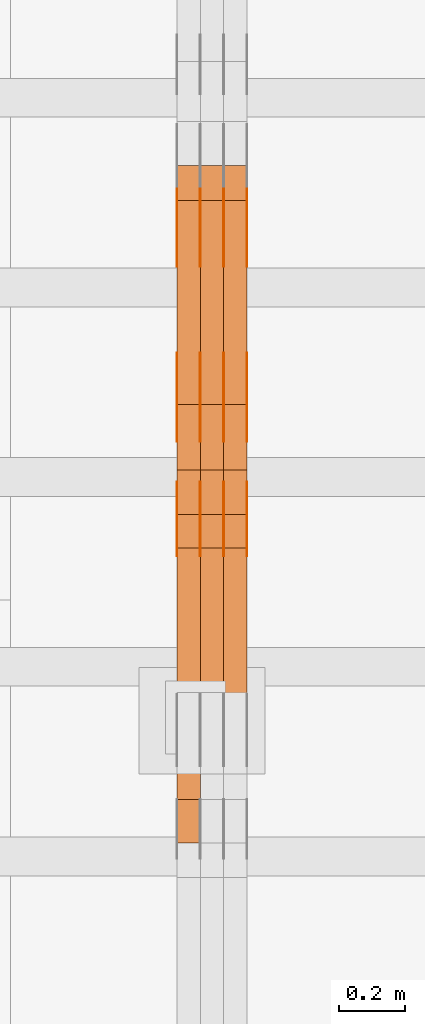
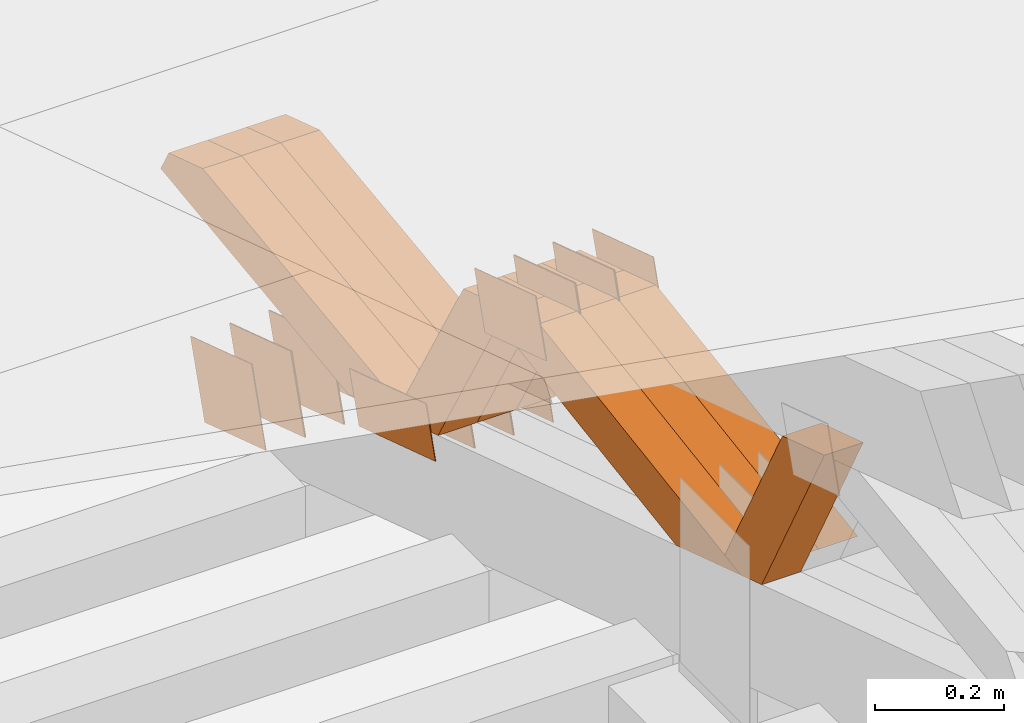
# One storey, part 164 of 385: 28 proxies.
"""IFC2X3 building model written with IfcOpenShell, lengths in millimetres."""

from ifc_helpers import new_model, entity, si_unit, converted_unit, derived_unit, direction, frame, origin, place, context, subcontext, project, spatial, polyline, outline, extrude, source, transform, mapped, material, type_object, type_shapes, element, save


model = new_model("IFC2X3")

# Units and contexts
model_context = context("Model", 3, precision=0.01, world=origin(), true_north=direction((6.12303176911189e-17, 1.0)))
body_context = subcontext(model_context, "Body", "Model", "MODEL_VIEW")
ifc_project = project(units=[si_unit("LENGTHUNIT", "METRE", prefix="MILLI"), si_unit("AREAUNIT", "SQUARE_METRE"), si_unit("VOLUMEUNIT", "CUBIC_METRE"), converted_unit("PLANEANGLEUNIT", "DEGREE", entity("IfcRatioMeasure", 0.0174532925199433), si_unit("PLANEANGLEUNIT", "RADIAN"), dimensions=[0, 0, 0, 0, 0, 0, 0]), si_unit("MASSUNIT", "GRAM", prefix="KILO"), derived_unit("MASSDENSITYUNIT", [(si_unit("MASSUNIT", "GRAM", prefix="KILO"), 1), (si_unit("LENGTHUNIT", "METRE"), -3)]), si_unit("TIMEUNIT", "SECOND"), si_unit("FREQUENCYUNIT", "HERTZ"), si_unit("THERMODYNAMICTEMPERATUREUNIT", "DEGREE_CELSIUS"), derived_unit("THERMALTRANSMITTANCEUNIT", [(si_unit("MASSUNIT", "GRAM", prefix="KILO"), 1), (si_unit("THERMODYNAMICTEMPERATUREUNIT", "KELVIN"), -1), (si_unit("TIMEUNIT", "SECOND"), -3)]), derived_unit("VOLUMETRICFLOWRATEUNIT", [(si_unit("LENGTHUNIT", "METRE"), 3), (si_unit("TIMEUNIT", "SECOND"), -1)]), si_unit("ELECTRICCURRENTUNIT", "AMPERE"), si_unit("ELECTRICVOLTAGEUNIT", "VOLT"), si_unit("POWERUNIT", "WATT"), si_unit("FORCEUNIT", "NEWTON", prefix="KILO"), si_unit("ILLUMINANCEUNIT", "LUX"), si_unit("LUMINOUSFLUXUNIT", "LUMEN"), si_unit("LUMINOUSINTENSITYUNIT", "CANDELA"), derived_unit("USERDEFINED", [(si_unit("MASSUNIT", "GRAM", prefix="KILO"), -1), (si_unit("LENGTHUNIT", "METRE"), -2), (si_unit("TIMEUNIT", "SECOND"), 3), (si_unit("LUMINOUSFLUXUNIT", "LUMEN"), 1)]), derived_unit("LINEARVELOCITYUNIT", [(si_unit("LENGTHUNIT", "METRE"), 1), (si_unit("TIMEUNIT", "SECOND"), -1)]), si_unit("PRESSUREUNIT", "PASCAL"), derived_unit("USERDEFINED", [(si_unit("LENGTHUNIT", "METRE"), -2), (si_unit("MASSUNIT", "GRAM", prefix="KILO"), 1), (si_unit("TIMEUNIT", "SECOND"), -2)])], contexts=[model_context])

# Site, building, storey
site_placement = place(None, origin())
site = spatial("IfcSite", under=ifc_project, at=site_placement, CompositionType="ELEMENT")
building_placement = place(site_placement, origin())
building = spatial("IfcBuilding", under=site, at=building_placement, CompositionType="ELEMENT")
storey_placement = place(building_placement, origin())
storey = spatial("IfcBuildingStorey", under=building, at=storey_placement, Name="Default", CompositionType="ELEMENT", Elevation=0.0)

# Proxies
ifc_material_1 = material(Name="IfcSurfaceStyle #307990")
building_element_proxy_type_1 = type_object("IfcBuildingElementProxyType", PredefinedType="NOTDEFINED", material=ifc_material_1)
shared_shape_1 = source(origin(), body_context, "Body", "SweptSolid", [
    extrude(outline(polyline([(-125.00031378339, -47.9999612158856), (125.000225258022, -47.9999612158856), (124.999811678525, 47.9999612158856), (-124.999723153156, 47.9999612158856), (-125.00031378339, -47.9999612158856)])), frame((125.000225258022, 48.0000091013474, 0.0), z_axis=(0.0, 0.0, 1.0), x_axis=(-1.0, 0.0, 0.0)), (0.0, 0.0, 1.0), 1.3),
])
type_shapes(building_element_proxy_type_1, [shared_shape_1])
proxy_1_placement = place(building_placement, frame((24386.3, 18456.8597683375, 2657.46691321253), z_axis=(-1.0, 0.0, 0.0), x_axis=(0.0, -0.951056516295124, 0.309016994375039)))
element("IfcBuildingElementProxy", 1, at=proxy_1_placement, inside=storey, type_object=building_element_proxy_type_1, material=ifc_material_1, context=body_context, shape_type="MappedRepresentation", body=[
    mapped(shared_shape_1, transform((0.0, 0.0, 0.0), scale=1.0)),
])
ifc_material_2 = material(Name="IfcSurfaceStyle #307933")
building_element_proxy_type_2 = type_object("IfcBuildingElementProxyType", PredefinedType="NOTDEFINED", material=ifc_material_2)
shared_shape_2 = source(origin(), body_context, "Body", "SweptSolid", [
    extrude(outline(polyline([(-125.00031378339, -47.9999612158856), (125.000225258022, -47.9999612158856), (124.999811678525, 47.9999612158856), (-124.999723153156, 47.9999612158856), (-125.00031378339, -47.9999612158856)])), frame((125.000225258022, 48.0000091013474, 0.0), z_axis=(0.0, 0.0, 1.0), x_axis=(-1.0, 0.0, 0.0)), (0.0, 0.0, 1.0), 1.3),
])
type_shapes(building_element_proxy_type_2, [shared_shape_2])
proxy_2_placement = place(building_placement, frame((24315.0, 18456.8597683375, 2657.46691321253), z_axis=(-1.0, 0.0, 0.0), x_axis=(0.0, -0.951056516295124, 0.309016994375039)))
element("IfcBuildingElementProxy", 2, at=proxy_2_placement, inside=storey, type_object=building_element_proxy_type_2, material=ifc_material_2, context=body_context, shape_type="MappedRepresentation", body=[
    mapped(shared_shape_2, transform((0.0, 0.0, 0.0), scale=1.0)),
])
ifc_material_3 = material(Name="IfcSurfaceStyle #307876")
building_element_proxy_type_3 = type_object("IfcBuildingElementProxyType", PredefinedType="NOTDEFINED", material=ifc_material_3)
shared_shape_3 = source(origin(), body_context, "Body", "SweptSolid", [
    extrude(outline(polyline([(-125.00031378339, -47.9999612158856), (125.000225258022, -47.9999612158856), (124.999811678525, 47.9999612158856), (-124.999723153156, 47.9999612158856), (-125.00031378339, -47.9999612158856)])), frame((125.000225258022, 48.0000091013474, 0.0), z_axis=(0.0, 0.0, 1.0), x_axis=(-1.0, 0.0, 0.0)), (0.0, 0.0, 1.0), 1.3),
])
type_shapes(building_element_proxy_type_3, [shared_shape_3])
proxy_3_placement = place(building_placement, frame((24316.3, 18456.8597683375, 2657.46691321253), z_axis=(-1.0, 0.0, 0.0), x_axis=(0.0, -0.951056516295124, 0.309016994375039)))
element("IfcBuildingElementProxy", 3, at=proxy_3_placement, inside=storey, type_object=building_element_proxy_type_3, material=ifc_material_3, context=body_context, shape_type="MappedRepresentation", body=[
    mapped(shared_shape_3, transform((0.0, 0.0, 0.0), scale=1.0)),
])
ifc_material_4 = material(Name="IfcSurfaceStyle #307819")
building_element_proxy_type_4 = type_object("IfcBuildingElementProxyType", PredefinedType="NOTDEFINED", material=ifc_material_4)
shared_shape_4 = source(origin(), body_context, "Body", "SweptSolid", [
    extrude(outline(polyline([(-125.00031378339, -47.9999612158856), (125.000225258022, -47.9999612158856), (124.999811678525, 47.9999612158856), (-124.999723153156, 47.9999612158856), (-125.00031378339, -47.9999612158856)])), frame((125.000225258022, 48.0000091013474, 0.0), z_axis=(0.0, 0.0, 1.0), x_axis=(-1.0, 0.0, 0.0)), (0.0, 0.0, 1.0), 1.29999999999998),
])
type_shapes(building_element_proxy_type_4, [shared_shape_4])
proxy_4_placement = place(building_placement, frame((24245.0, 18456.8597683375, 2657.46691321253), z_axis=(-1.0, 0.0, 0.0), x_axis=(0.0, -0.951056516295124, 0.309016994375039)))
element("IfcBuildingElementProxy", 4, at=proxy_4_placement, inside=storey, type_object=building_element_proxy_type_4, material=ifc_material_4, context=body_context, shape_type="MappedRepresentation", body=[
    mapped(shared_shape_4, transform((0.0, 0.0, 0.0), scale=1.0)),
])
ifc_material_5 = material(Name="IfcSurfaceStyle #307762")
building_element_proxy_type_5 = type_object("IfcBuildingElementProxyType", PredefinedType="NOTDEFINED", material=ifc_material_5)
shared_shape_5 = source(origin(), body_context, "Body", "SweptSolid", [
    extrude(outline(polyline([(-125.00031378339, -47.9999612158856), (125.000225258022, -47.9999612158856), (124.999811678525, 47.9999612158856), (-124.999723153156, 47.9999612158856), (-125.00031378339, -47.9999612158856)])), frame((125.000225258022, 48.0000091013474, 0.0), z_axis=(0.0, 0.0, 1.0), x_axis=(-1.0, 0.0, 0.0)), (0.0, 0.0, 1.0), 1.29999999999998),
])
type_shapes(building_element_proxy_type_5, [shared_shape_5])
proxy_5_placement = place(building_placement, frame((24246.3, 18456.8597683375, 2657.46691321253), z_axis=(-1.0, 0.0, 0.0), x_axis=(0.0, -0.951056516295124, 0.309016994375039)))
element("IfcBuildingElementProxy", 5, at=proxy_5_placement, inside=storey, type_object=building_element_proxy_type_5, material=ifc_material_5, context=body_context, shape_type="MappedRepresentation", body=[
    mapped(shared_shape_5, transform((0.0, 0.0, 0.0), scale=1.0)),
])
ifc_material_6 = material(Name="IfcSurfaceStyle #307705")
building_element_proxy_type_6 = type_object("IfcBuildingElementProxyType", PredefinedType="NOTDEFINED", material=ifc_material_6)
shared_shape_6 = source(origin(), body_context, "Body", "SweptSolid", [
    extrude(outline(polyline([(-125.00031378339, -47.9999612158856), (125.000225258022, -47.9999612158856), (124.999811678525, 47.9999612158856), (-124.999723153156, 47.9999612158856), (-125.00031378339, -47.9999612158856)])), frame((125.000225258022, 48.0000091013474, 0.0), z_axis=(0.0, 0.0, 1.0), x_axis=(-1.0, 0.0, 0.0)), (0.0, 0.0, 1.0), 1.29999999999998),
])
type_shapes(building_element_proxy_type_6, [shared_shape_6])
proxy_6_placement = place(building_placement, frame((24175.0, 18456.8597683375, 2657.46691321253), z_axis=(-1.0, 0.0, 0.0), x_axis=(0.0, -0.951056516295124, 0.309016994375039)))
element("IfcBuildingElementProxy", 6, at=proxy_6_placement, inside=storey, type_object=building_element_proxy_type_6, material=ifc_material_6, context=body_context, shape_type="MappedRepresentation", body=[
    mapped(shared_shape_6, transform((0.0, 0.0, 0.0), scale=1.0)),
])
ifc_material_7 = material(Name="IfcSurfaceStyle #306280")
building_element_proxy_type_7 = type_object("IfcBuildingElementProxyType", PredefinedType="NOTDEFINED", material=ifc_material_7)
shared_shape_7 = source(origin(), body_context, "Body", "SweptSolid", [
    extrude(outline(polyline([(-99.999796294464, -72.0000050220467), (99.9998768370438, -72.0000050220467), (100.000260677528, 72.0000050220467), (-100.000341220108, 72.0000050220467), (-99.999796294464, -72.0000050220467)])), frame((100.000260677528, 72.0000050220467, 0.0), z_axis=(0.0, 0.0, 1.0), x_axis=(-1.0, 0.0, 0.0)), (0.0, 0.0, 1.0), 1.3),
])
type_shapes(building_element_proxy_type_7, [shared_shape_7])
proxy_7_placement = place(building_placement, frame((24386.3, 18936.3876569477, 2373.90613192527), z_axis=(-1.0, 0.0, 0.0), x_axis=(0.0, -0.951056516295124, 0.309016994375039)))
element("IfcBuildingElementProxy", 7, at=proxy_7_placement, inside=storey, type_object=building_element_proxy_type_7, material=ifc_material_7, context=body_context, shape_type="MappedRepresentation", body=[
    mapped(shared_shape_7, transform((0.0, 0.0, 0.0), scale=1.0)),
])
ifc_material_8 = material(Name="IfcSurfaceStyle #306223")
building_element_proxy_type_8 = type_object("IfcBuildingElementProxyType", PredefinedType="NOTDEFINED", material=ifc_material_8)
shared_shape_8 = source(origin(), body_context, "Body", "SweptSolid", [
    extrude(outline(polyline([(-99.999796294464, -72.0000050220467), (99.9998768370438, -72.0000050220467), (100.000260677528, 72.0000050220467), (-100.000341220108, 72.0000050220467), (-99.999796294464, -72.0000050220467)])), frame((100.000260677528, 72.0000050220467, 0.0), z_axis=(0.0, 0.0, 1.0), x_axis=(-1.0, 0.0, 0.0)), (0.0, 0.0, 1.0), 1.3),
])
type_shapes(building_element_proxy_type_8, [shared_shape_8])
proxy_8_placement = place(building_placement, frame((24315.0, 18936.3876569477, 2373.90613192527), z_axis=(-1.0, 0.0, 0.0), x_axis=(0.0, -0.951056516295124, 0.309016994375039)))
element("IfcBuildingElementProxy", 8, at=proxy_8_placement, inside=storey, type_object=building_element_proxy_type_8, material=ifc_material_8, context=body_context, shape_type="MappedRepresentation", body=[
    mapped(shared_shape_8, transform((0.0, 0.0, 0.0), scale=1.0)),
])
ifc_material_9 = material(Name="IfcSurfaceStyle #306166")
building_element_proxy_type_9 = type_object("IfcBuildingElementProxyType", PredefinedType="NOTDEFINED", material=ifc_material_9)
shared_shape_9 = source(origin(), body_context, "Body", "SweptSolid", [
    extrude(outline(polyline([(-99.999796294464, -72.0000050220467), (99.9998768370438, -72.0000050220467), (100.000260677528, 72.0000050220467), (-100.000341220108, 72.0000050220467), (-99.999796294464, -72.0000050220467)])), frame((100.000260677528, 72.0000050220467, 0.0), z_axis=(0.0, 0.0, 1.0), x_axis=(-1.0, 0.0, 0.0)), (0.0, 0.0, 1.0), 1.3),
])
type_shapes(building_element_proxy_type_9, [shared_shape_9])
proxy_9_placement = place(building_placement, frame((24316.3, 18936.3876569477, 2373.90613192527), z_axis=(-1.0, 0.0, 0.0), x_axis=(0.0, -0.951056516295124, 0.309016994375039)))
element("IfcBuildingElementProxy", 9, at=proxy_9_placement, inside=storey, type_object=building_element_proxy_type_9, material=ifc_material_9, context=body_context, shape_type="MappedRepresentation", body=[
    mapped(shared_shape_9, transform((0.0, 0.0, 0.0), scale=1.0)),
])
ifc_material_10 = material(Name="IfcSurfaceStyle #306109")
building_element_proxy_type_10 = type_object("IfcBuildingElementProxyType", PredefinedType="NOTDEFINED", material=ifc_material_10)
shared_shape_10 = source(origin(), body_context, "Body", "SweptSolid", [
    extrude(outline(polyline([(-99.999796294464, -72.0000050220467), (99.9998768370438, -72.0000050220467), (100.000260677528, 72.0000050220467), (-100.000341220108, 72.0000050220467), (-99.999796294464, -72.0000050220467)])), frame((100.000260677528, 72.0000050220467, 0.0), z_axis=(0.0, 0.0, 1.0), x_axis=(-1.0, 0.0, 0.0)), (0.0, 0.0, 1.0), 1.29999999999998),
])
type_shapes(building_element_proxy_type_10, [shared_shape_10])
proxy_10_placement = place(building_placement, frame((24245.0, 18936.3876569477, 2373.90613192527), z_axis=(-1.0, 0.0, 0.0), x_axis=(0.0, -0.951056516295124, 0.309016994375039)))
element("IfcBuildingElementProxy", 10, at=proxy_10_placement, inside=storey, type_object=building_element_proxy_type_10, material=ifc_material_10, context=body_context, shape_type="MappedRepresentation", body=[
    mapped(shared_shape_10, transform((0.0, 0.0, 0.0), scale=1.0)),
])
ifc_material_11 = material(Name="IfcSurfaceStyle #306052")
building_element_proxy_type_11 = type_object("IfcBuildingElementProxyType", PredefinedType="NOTDEFINED", material=ifc_material_11)
shared_shape_11 = source(origin(), body_context, "Body", "SweptSolid", [
    extrude(outline(polyline([(-99.999796294464, -72.0000050220467), (99.9998768370438, -72.0000050220467), (100.000260677528, 72.0000050220467), (-100.000341220108, 72.0000050220467), (-99.999796294464, -72.0000050220467)])), frame((100.000260677528, 72.0000050220467, 0.0), z_axis=(0.0, 0.0, 1.0), x_axis=(-1.0, 0.0, 0.0)), (0.0, 0.0, 1.0), 1.29999999999998),
])
type_shapes(building_element_proxy_type_11, [shared_shape_11])
proxy_11_placement = place(building_placement, frame((24246.3, 18936.3876569477, 2373.90613192527), z_axis=(-1.0, 0.0, 0.0), x_axis=(0.0, -0.951056516295124, 0.309016994375039)))
element("IfcBuildingElementProxy", 11, at=proxy_11_placement, inside=storey, type_object=building_element_proxy_type_11, material=ifc_material_11, context=body_context, shape_type="MappedRepresentation", body=[
    mapped(shared_shape_11, transform((0.0, 0.0, 0.0), scale=1.0)),
])
ifc_material_12 = material(Name="IfcSurfaceStyle #305995")
building_element_proxy_type_12 = type_object("IfcBuildingElementProxyType", PredefinedType="NOTDEFINED", material=ifc_material_12)
shared_shape_12 = source(origin(), body_context, "Body", "SweptSolid", [
    extrude(outline(polyline([(-99.999796294464, -72.0000050220467), (99.9998768370438, -72.0000050220467), (100.000260677528, 72.0000050220467), (-100.000341220108, 72.0000050220467), (-99.999796294464, -72.0000050220467)])), frame((100.000260677528, 72.0000050220467, 0.0), z_axis=(0.0, 0.0, 1.0), x_axis=(-1.0, 0.0, 0.0)), (0.0, 0.0, 1.0), 1.29999999999999),
])
type_shapes(building_element_proxy_type_12, [shared_shape_12])
proxy_12_placement = place(building_placement, frame((24175.0, 18936.3876569477, 2373.90613192527), z_axis=(-1.0, 0.0, 0.0), x_axis=(0.0, -0.951056516295124, 0.309016994375039)))
element("IfcBuildingElementProxy", 12, at=proxy_12_placement, inside=storey, type_object=building_element_proxy_type_12, material=ifc_material_12, context=body_context, shape_type="MappedRepresentation", body=[
    mapped(shared_shape_12, transform((0.0, 0.0, 0.0), scale=1.0)),
])
ifc_material_13 = material(Name="IfcSurfaceStyle #301834")
building_element_proxy_type_13 = type_object("IfcBuildingElementProxyType", PredefinedType="NOTDEFINED", material=ifc_material_13)
shared_shape_13 = source(origin(), body_context, "Body", "SweptSolid", [
    extrude(outline(polyline([(-99.9999427841299, -54.0000599375792), (99.9996549037756, -54.0000599375792), (100.000407167194, 54.0000599375792), (-100.00011928684, 54.0000599375792), (-99.9999427841299, -54.0000599375792)])), frame((100.000407167194, 54.0000599375792, 0.0), z_axis=(0.0, 0.0, 1.0), x_axis=(-1.0, 0.0, 0.0)), (0.0, 0.0, 1.0), 1.3),
])
type_shapes(building_element_proxy_type_13, [shared_shape_13])
proxy_13_placement = place(building_placement, frame((24386.3, 18065.0682492591, 3072.55239547302), z_axis=(-1.0, 0.0, 0.0), x_axis=(0.0, -0.951056516295154, 0.309016994374948)))
element("IfcBuildingElementProxy", 13, at=proxy_13_placement, inside=storey, type_object=building_element_proxy_type_13, material=ifc_material_13, context=body_context, shape_type="MappedRepresentation", body=[
    mapped(shared_shape_13, transform((0.0, 0.0, 0.0), scale=1.0)),
])
ifc_material_14 = material(Name="IfcSurfaceStyle #301777")
building_element_proxy_type_14 = type_object("IfcBuildingElementProxyType", PredefinedType="NOTDEFINED", material=ifc_material_14)
shared_shape_14 = source(origin(), body_context, "Body", "SweptSolid", [
    extrude(outline(polyline([(-99.9999427841299, -54.0000599375792), (99.9996549037756, -54.0000599375792), (100.000407167194, 54.0000599375792), (-100.00011928684, 54.0000599375792), (-99.9999427841299, -54.0000599375792)])), frame((100.000407167194, 54.0000599375792, 0.0), z_axis=(0.0, 0.0, 1.0), x_axis=(-1.0, 0.0, 0.0)), (0.0, 0.0, 1.0), 1.3),
])
type_shapes(building_element_proxy_type_14, [shared_shape_14])
proxy_14_placement = place(building_placement, frame((24315.0, 18065.0682492591, 3072.55239547302), z_axis=(-1.0, 0.0, 0.0), x_axis=(0.0, -0.951056516295154, 0.309016994374948)))
element("IfcBuildingElementProxy", 14, at=proxy_14_placement, inside=storey, type_object=building_element_proxy_type_14, material=ifc_material_14, context=body_context, shape_type="MappedRepresentation", body=[
    mapped(shared_shape_14, transform((0.0, 0.0, 0.0), scale=1.0)),
])
ifc_material_15 = material(Name="IfcSurfaceStyle #301720")
building_element_proxy_type_15 = type_object("IfcBuildingElementProxyType", PredefinedType="NOTDEFINED", material=ifc_material_15)
shared_shape_15 = source(origin(), body_context, "Body", "SweptSolid", [
    extrude(outline(polyline([(-99.9999427841299, -54.0000599375792), (99.9996549037756, -54.0000599375792), (100.000407167194, 54.0000599375792), (-100.00011928684, 54.0000599375792), (-99.9999427841299, -54.0000599375792)])), frame((100.000407167194, 54.0000599375792, 0.0), z_axis=(0.0, 0.0, 1.0), x_axis=(-1.0, 0.0, 0.0)), (0.0, 0.0, 1.0), 1.3),
])
type_shapes(building_element_proxy_type_15, [shared_shape_15])
proxy_15_placement = place(building_placement, frame((24316.3, 18065.0682492591, 3072.55239547302), z_axis=(-1.0, 0.0, 0.0), x_axis=(0.0, -0.951056516295154, 0.309016994374948)))
element("IfcBuildingElementProxy", 15, at=proxy_15_placement, inside=storey, type_object=building_element_proxy_type_15, material=ifc_material_15, context=body_context, shape_type="MappedRepresentation", body=[
    mapped(shared_shape_15, transform((0.0, 0.0, 0.0), scale=1.0)),
])
ifc_material_16 = material(Name="IfcSurfaceStyle #301663")
building_element_proxy_type_16 = type_object("IfcBuildingElementProxyType", PredefinedType="NOTDEFINED", material=ifc_material_16)
shared_shape_16 = source(origin(), body_context, "Body", "SweptSolid", [
    extrude(outline(polyline([(-99.9999427841299, -54.0000599375792), (99.9996549037756, -54.0000599375792), (100.000407167194, 54.0000599375792), (-100.00011928684, 54.0000599375792), (-99.9999427841299, -54.0000599375792)])), frame((100.000407167194, 54.0000599375792, 0.0), z_axis=(0.0, 0.0, 1.0), x_axis=(-1.0, 0.0, 0.0)), (0.0, 0.0, 1.0), 1.29999999999998),
])
type_shapes(building_element_proxy_type_16, [shared_shape_16])
proxy_16_placement = place(building_placement, frame((24245.0, 18065.0682492591, 3072.55239547302), z_axis=(-1.0, 0.0, 0.0), x_axis=(0.0, -0.951056516295154, 0.309016994374948)))
element("IfcBuildingElementProxy", 16, at=proxy_16_placement, inside=storey, type_object=building_element_proxy_type_16, material=ifc_material_16, context=body_context, shape_type="MappedRepresentation", body=[
    mapped(shared_shape_16, transform((0.0, 0.0, 0.0), scale=1.0)),
])
ifc_material_17 = material(Name="IfcSurfaceStyle #301606")
building_element_proxy_type_17 = type_object("IfcBuildingElementProxyType", PredefinedType="NOTDEFINED", material=ifc_material_17)
shared_shape_17 = source(origin(), body_context, "Body", "SweptSolid", [
    extrude(outline(polyline([(-99.9999427841299, -54.0000599375792), (99.9996549037756, -54.0000599375792), (100.000407167194, 54.0000599375792), (-100.00011928684, 54.0000599375792), (-99.9999427841299, -54.0000599375792)])), frame((100.000407167194, 54.0000599375792, 0.0), z_axis=(0.0, 0.0, 1.0), x_axis=(-1.0, 0.0, 0.0)), (0.0, 0.0, 1.0), 1.29999999999998),
])
type_shapes(building_element_proxy_type_17, [shared_shape_17])
proxy_17_placement = place(building_placement, frame((24246.3, 18065.0682492591, 3072.55239547302), z_axis=(-1.0, 0.0, 0.0), x_axis=(0.0, -0.951056516295154, 0.309016994374948)))
element("IfcBuildingElementProxy", 17, at=proxy_17_placement, inside=storey, type_object=building_element_proxy_type_17, material=ifc_material_17, context=body_context, shape_type="MappedRepresentation", body=[
    mapped(shared_shape_17, transform((0.0, 0.0, 0.0), scale=1.0)),
])
ifc_material_18 = material(Name="IfcSurfaceStyle #301549")
building_element_proxy_type_18 = type_object("IfcBuildingElementProxyType", PredefinedType="NOTDEFINED", material=ifc_material_18)
shared_shape_18 = source(origin(), body_context, "Body", "SweptSolid", [
    extrude(outline(polyline([(-99.9999427841299, -54.0000599375792), (99.9996549037756, -54.0000599375792), (100.000407167194, 54.0000599375792), (-100.00011928684, 54.0000599375792), (-99.9999427841299, -54.0000599375792)])), frame((100.000407167194, 54.0000599375792, 0.0), z_axis=(0.0, 0.0, 1.0), x_axis=(-1.0, 0.0, 0.0)), (0.0, 0.0, 1.0), 1.29999999999999),
])
type_shapes(building_element_proxy_type_18, [shared_shape_18])
proxy_18_placement = place(building_placement, frame((24175.0, 18065.0682492591, 3072.55239547302), z_axis=(-1.0, 0.0, 0.0), x_axis=(0.0, -0.951056516295154, 0.309016994374948)))
element("IfcBuildingElementProxy", 18, at=proxy_18_placement, inside=storey, type_object=building_element_proxy_type_18, material=ifc_material_18, context=body_context, shape_type="MappedRepresentation", body=[
    mapped(shared_shape_18, transform((0.0, 0.0, 0.0), scale=1.0)),
])
ifc_material_19 = material(Name="IfcSurfaceStyle #292342")
building_element_proxy_type_19 = type_object("IfcBuildingElementProxyType", Name="T1-W39 292340", PredefinedType="NOTDEFINED", material=ifc_material_19)
shared_shape_19 = source(origin(), body_context, "Body", "SweptSolid", [
    extrude(outline(polyline([(-191.519946663886, -47.499928106579), (188.32936223763, -47.499928106579), (171.597440144109, 0.000249483340993841), (122.102882529753, 47.4998033649085), (-290.509738247605, 47.4998033649085), (-191.519946663886, -47.499928106579)])), frame((188.329593252001, 47.499957247623, 0.0), z_axis=(0.0, 0.0, 1.0), x_axis=(-1.0, 0.0, 0.0)), (0.0, 0.0, 1.0), 70.0),
])
type_shapes(building_element_proxy_type_19, [shared_shape_19])
proxy_19_placement = place(building_placement, frame((24245.0, 17238.5876916597, 3055.56121424762), z_axis=(-1.0, 0.0, 0.0), x_axis=(0.0, -0.472216932390777, 0.881482370080902)))
element("IfcBuildingElementProxy", 19, at=proxy_19_placement, inside=storey, type_object=building_element_proxy_type_19, material=ifc_material_19, Name="T1-W39", context=body_context, shape_type="MappedRepresentation", body=[
    mapped(shared_shape_19, transform((0.0, 0.0, 0.0), scale=1.0)),
])
ifc_material_20 = material(Name="IfcSurfaceStyle #292078")
building_element_proxy_type_20 = type_object("IfcBuildingElementProxyType", Name="T1-W10 292076", PredefinedType="NOTDEFINED", material=ifc_material_20)
shared_shape_20 = source(origin(), body_context, "Body", "SweptSolid", [
    extrude(outline(polyline([(-459.546036710757, -47.5000436364511), (174.689450869018, -47.5000436364511), (268.831081103959, 0.00011114562912502), (287.286350706789, 47.4999880636365), (-271.260845969009, 47.4999880636366), (-459.546036710757, -47.5000436364511)])), frame((287.286768781132, 47.5001637448091, 0.0), z_axis=(0.0, 0.0, 1.0), x_axis=(-1.0, 0.0, 0.0)), (0.0, 0.0, 1.0), 70.0),
])
type_shapes(building_element_proxy_type_20, [shared_shape_20])
proxy_20_placement = place(building_placement, frame((24385.0, 18025.1410649788, 3112.76453857986), z_axis=(-1.0, 0.0, 0.0), x_axis=(0.0, -0.988299196256916, -0.152527698068035)))
element("IfcBuildingElementProxy", 20, at=proxy_20_placement, inside=storey, type_object=building_element_proxy_type_20, material=ifc_material_20, Name="T1-W10", context=body_context, shape_type="MappedRepresentation", body=[
    mapped(shared_shape_20, transform((0.0, 0.0, 0.0), scale=1.0)),
])
ifc_material_21 = material(Name="IfcSurfaceStyle #292012")
building_element_proxy_type_21 = type_object("IfcBuildingElementProxyType", Name="T1-W10 292010", PredefinedType="NOTDEFINED", material=ifc_material_21)
shared_shape_21 = source(origin(), body_context, "Body", "SweptSolid", [
    extrude(outline(polyline([(-459.546036710757, -47.5000436364511), (174.689450869018, -47.5000436364511), (268.831081103959, 0.00011114562912502), (287.286350706789, 47.4999880636365), (-271.260845969009, 47.4999880636366), (-459.546036710757, -47.5000436364511)])), frame((287.286768781132, 47.5001637448091, 0.0), z_axis=(0.0, 0.0, 1.0), x_axis=(-1.0, 0.0, 0.0)), (0.0, 0.0, 1.0), 70.0),
])
type_shapes(building_element_proxy_type_21, [shared_shape_21])
proxy_21_placement = place(building_placement, frame((24315.0, 18025.1410649788, 3112.76453857986), z_axis=(-1.0, 0.0, 0.0), x_axis=(0.0, -0.988299196256916, -0.152527698068035)))
element("IfcBuildingElementProxy", 21, at=proxy_21_placement, inside=storey, type_object=building_element_proxy_type_21, material=ifc_material_21, Name="T1-W10", context=body_context, shape_type="MappedRepresentation", body=[
    mapped(shared_shape_21, transform((0.0, 0.0, 0.0), scale=1.0)),
])
ifc_material_22 = material(Name="IfcSurfaceStyle #291946")
building_element_proxy_type_22 = type_object("IfcBuildingElementProxyType", Name="T1-W10 291944", PredefinedType="NOTDEFINED", material=ifc_material_22)
shared_shape_22 = source(origin(), body_context, "Body", "SweptSolid", [
    extrude(outline(polyline([(-459.546036710757, -47.5000436364511), (174.689450869018, -47.5000436364511), (268.831081103959, 0.00011114562912502), (287.286350706789, 47.4999880636365), (-271.260845969009, 47.4999880636366), (-459.546036710757, -47.5000436364511)])), frame((287.286768781132, 47.5001637448091, 0.0), z_axis=(0.0, 0.0, 1.0), x_axis=(-1.0, 0.0, 0.0)), (0.0, 0.0, 1.0), 70.0),
])
type_shapes(building_element_proxy_type_22, [shared_shape_22])
proxy_22_placement = place(building_placement, frame((24245.0, 18025.1410649788, 3112.76453857986), z_axis=(-1.0, 0.0, 0.0), x_axis=(0.0, -0.988299196256916, -0.152527698068035)))
element("IfcBuildingElementProxy", 22, at=proxy_22_placement, inside=storey, type_object=building_element_proxy_type_22, material=ifc_material_22, Name="T1-W10", context=body_context, shape_type="MappedRepresentation", body=[
    mapped(shared_shape_22, transform((0.0, 0.0, 0.0), scale=1.0)),
])
ifc_material_23 = material(Name="IfcSurfaceStyle #291682")
building_element_proxy_type_23 = type_object("IfcBuildingElementProxyType", Name="T1-W35 291680", PredefinedType="NOTDEFINED", material=ifc_material_23)
shared_shape_23 = source(origin(), body_context, "Body", "SweptSolid", [
    extrude(outline(polyline([(-196.877231354918, -47.499850828051), (197.289756738813, -47.499850828051), (177.380838136073, -0.000131002767018074), (124.615181369032, 47.4999163294346), (-302.408544889, 47.4999163294346), (-196.877231354918, -47.499850828051)])), frame((197.289756738813, 47.5002438363521, 0.0), z_axis=(0.0, 0.0, 1.0), x_axis=(-1.0, 0.0, 0.0)), (0.0, 0.0, 1.0), 70.0),
])
type_shapes(building_element_proxy_type_23, [shared_shape_23])
proxy_23_placement = place(building_placement, frame((24385.0, 18249.5528960018, 2724.16980022534), z_axis=(-1.0, 0.0, 0.0), x_axis=(0.0, -0.5, 0.866025403784439)))
element("IfcBuildingElementProxy", 23, at=proxy_23_placement, inside=storey, type_object=building_element_proxy_type_23, material=ifc_material_23, Name="T1-W35", context=body_context, shape_type="MappedRepresentation", body=[
    mapped(shared_shape_23, transform((0.0, 0.0, 0.0), scale=1.0)),
])
ifc_material_24 = material(Name="IfcSurfaceStyle #291616")
building_element_proxy_type_24 = type_object("IfcBuildingElementProxyType", Name="T1-W35 291614", PredefinedType="NOTDEFINED", material=ifc_material_24)
shared_shape_24 = source(origin(), body_context, "Body", "SweptSolid", [
    extrude(outline(polyline([(-196.877231354918, -47.499850828051), (197.289756738813, -47.499850828051), (177.380838136073, -0.000131002767018074), (124.615181369032, 47.4999163294346), (-302.408544889, 47.4999163294346), (-196.877231354918, -47.499850828051)])), frame((197.289756738813, 47.5002438363521, 0.0), z_axis=(0.0, 0.0, 1.0), x_axis=(-1.0, 0.0, 0.0)), (0.0, 0.0, 1.0), 70.0),
])
type_shapes(building_element_proxy_type_24, [shared_shape_24])
proxy_24_placement = place(building_placement, frame((24315.0, 18249.5528960018, 2724.16980022534), z_axis=(-1.0, 0.0, 0.0), x_axis=(0.0, -0.5, 0.866025403784439)))
element("IfcBuildingElementProxy", 24, at=proxy_24_placement, inside=storey, type_object=building_element_proxy_type_24, material=ifc_material_24, Name="T1-W35", context=body_context, shape_type="MappedRepresentation", body=[
    mapped(shared_shape_24, transform((0.0, 0.0, 0.0), scale=1.0)),
])
ifc_material_25 = material(Name="IfcSurfaceStyle #291550")
building_element_proxy_type_25 = type_object("IfcBuildingElementProxyType", Name="T1-W35 291548", PredefinedType="NOTDEFINED", material=ifc_material_25)
shared_shape_25 = source(origin(), body_context, "Body", "SweptSolid", [
    extrude(outline(polyline([(-196.877231354918, -47.499850828051), (197.289756738813, -47.499850828051), (177.380838136073, -0.000131002767018074), (124.615181369032, 47.4999163294346), (-302.408544889, 47.4999163294346), (-196.877231354918, -47.499850828051)])), frame((197.289756738813, 47.5002438363521, 0.0), z_axis=(0.0, 0.0, 1.0), x_axis=(-1.0, 0.0, 0.0)), (0.0, 0.0, 1.0), 70.0),
])
type_shapes(building_element_proxy_type_25, [shared_shape_25])
proxy_25_placement = place(building_placement, frame((24245.0, 18249.5528960018, 2724.16980022534), z_axis=(-1.0, 0.0, 0.0), x_axis=(0.0, -0.5, 0.866025403784439)))
element("IfcBuildingElementProxy", 25, at=proxy_25_placement, inside=storey, type_object=building_element_proxy_type_25, material=ifc_material_25, Name="T1-W35", context=body_context, shape_type="MappedRepresentation", body=[
    mapped(shared_shape_25, transform((0.0, 0.0, 0.0), scale=1.0)),
])
ifc_material_26 = material(Name="IfcSurfaceStyle #291286")
building_element_proxy_type_26 = type_object("IfcBuildingElementProxyType", Name="T1-W6 291284", PredefinedType="NOTDEFINED", material=ifc_material_26)
shared_shape_26 = source(origin(), body_context, "Body", "SweptSolid", [
    extrude(outline(polyline([(-485.945461934772, -47.500204767976), (183.41906495488, -47.500204767976), (284.061400026172, 0.000179660053988773), (303.127757064591, 47.500114937949), (-284.66276011087, 47.500114937949), (-485.945461934772, -47.500204767976)])), frame((303.127970456024, 47.5001450766485, 0.0), z_axis=(0.0, 0.0, 1.0), x_axis=(-1.0, 0.0, 0.0)), (0.0, 0.0, 1.0), 70.0),
])
type_shapes(building_element_proxy_type_26, [shared_shape_26])
proxy_26_placement = place(building_placement, frame((24385.0, 19075.4826373647, 2770.72729201433), z_axis=(-1.0, 0.0, 0.0), x_axis=(0.0, -0.991969529622927, -0.126477082112413)))
element("IfcBuildingElementProxy", 26, at=proxy_26_placement, inside=storey, type_object=building_element_proxy_type_26, material=ifc_material_26, Name="T1-W6", context=body_context, shape_type="MappedRepresentation", body=[
    mapped(shared_shape_26, transform((0.0, 0.0, 0.0), scale=1.0)),
])
ifc_material_27 = material(Name="IfcSurfaceStyle #291220")
building_element_proxy_type_27 = type_object("IfcBuildingElementProxyType", Name="T1-W6 291218", PredefinedType="NOTDEFINED", material=ifc_material_27)
shared_shape_27 = source(origin(), body_context, "Body", "SweptSolid", [
    extrude(outline(polyline([(-485.945461934772, -47.500204767976), (183.41906495488, -47.500204767976), (284.061400026172, 0.000179660053988773), (303.127757064591, 47.500114937949), (-284.66276011087, 47.500114937949), (-485.945461934772, -47.500204767976)])), frame((303.127970456024, 47.5001450766485, 0.0), z_axis=(0.0, 0.0, 1.0), x_axis=(-1.0, 0.0, 0.0)), (0.0, 0.0, 1.0), 70.0),
])
type_shapes(building_element_proxy_type_27, [shared_shape_27])
proxy_27_placement = place(building_placement, frame((24315.0, 19075.4826373647, 2770.72729201433), z_axis=(-1.0, 0.0, 0.0), x_axis=(0.0, -0.991969529622927, -0.126477082112413)))
element("IfcBuildingElementProxy", 27, at=proxy_27_placement, inside=storey, type_object=building_element_proxy_type_27, material=ifc_material_27, Name="T1-W6", context=body_context, shape_type="MappedRepresentation", body=[
    mapped(shared_shape_27, transform((0.0, 0.0, 0.0), scale=1.0)),
])
ifc_material_28 = material(Name="IfcSurfaceStyle #291154")
building_element_proxy_type_28 = type_object("IfcBuildingElementProxyType", Name="T1-W6 291152", PredefinedType="NOTDEFINED", material=ifc_material_28)
shared_shape_28 = source(origin(), body_context, "Body", "SweptSolid", [
    extrude(outline(polyline([(-485.945461934772, -47.500204767976), (183.41906495488, -47.500204767976), (284.061400026172, 0.000179660053988773), (303.127757064591, 47.500114937949), (-284.66276011087, 47.500114937949), (-485.945461934772, -47.500204767976)])), frame((303.127970456024, 47.5001450766485, 0.0), z_axis=(0.0, 0.0, 1.0), x_axis=(-1.0, 0.0, 0.0)), (0.0, 0.0, 1.0), 70.0),
])
type_shapes(building_element_proxy_type_28, [shared_shape_28])
proxy_28_placement = place(building_placement, frame((24245.0, 19075.4826373647, 2770.72729201433), z_axis=(-1.0, 0.0, 0.0), x_axis=(0.0, -0.991969529622927, -0.126477082112413)))
element("IfcBuildingElementProxy", 28, at=proxy_28_placement, inside=storey, type_object=building_element_proxy_type_28, material=ifc_material_28, Name="T1-W6", context=body_context, shape_type="MappedRepresentation", body=[
    mapped(shared_shape_28, transform((0.0, 0.0, 0.0), scale=1.0)),
])

save(model, "model.ifc")
